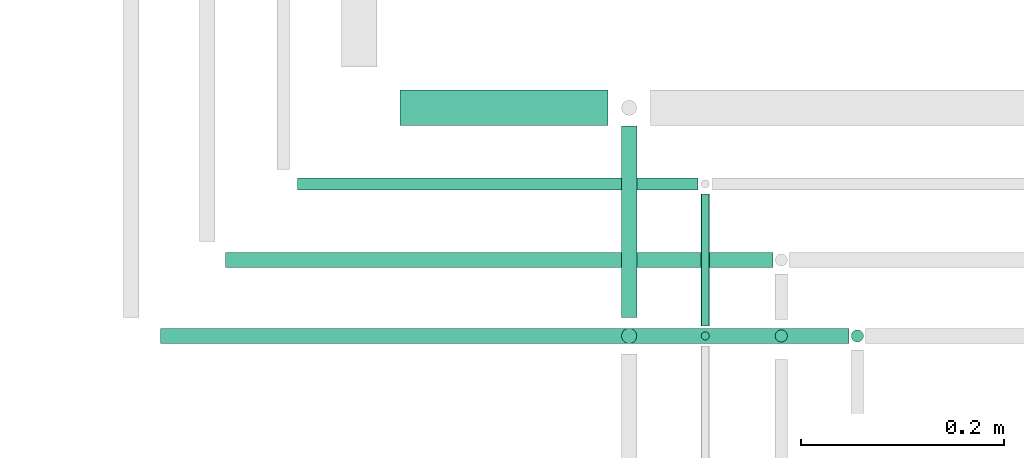
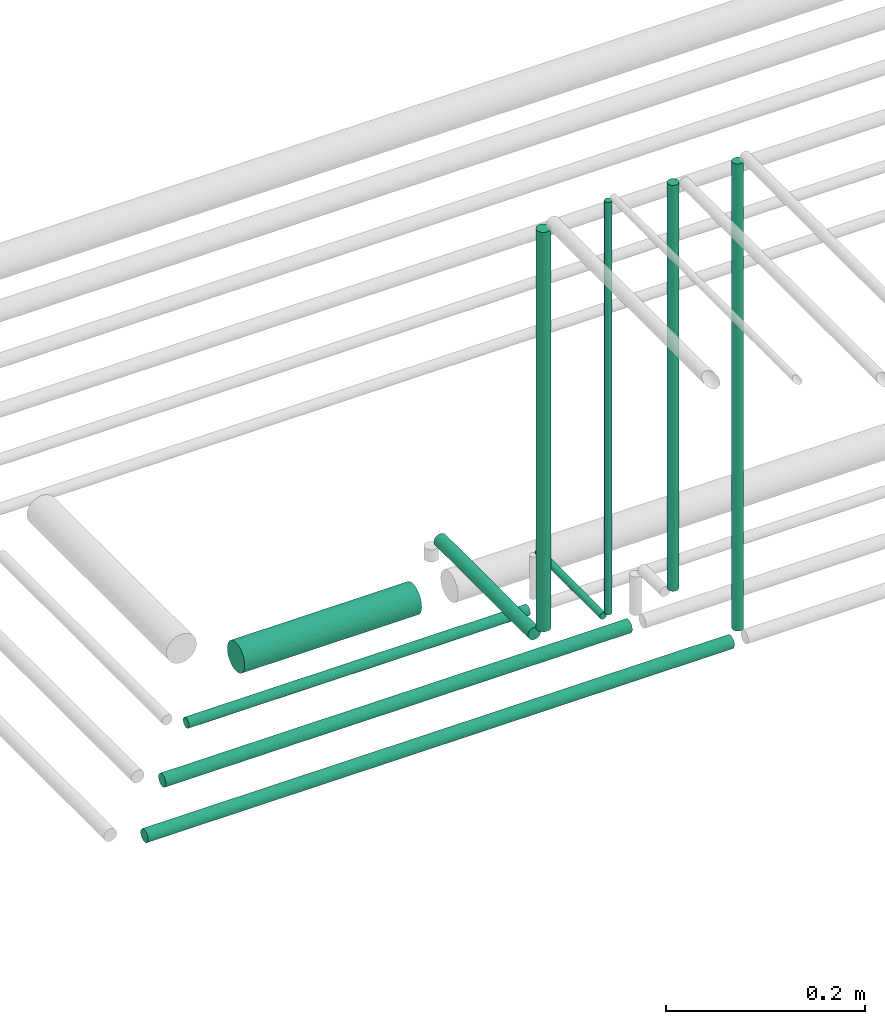
# One storey, part 41 of 65: 10 flow segments.
"""IFC2X3 building model written with IfcOpenShell, lengths in millimetres."""

from ifc_helpers import new_model, entity, si_unit, converted_unit, derived_unit, direction, frame, frame_2d, origin, origin_2d_with_axis, place, context, subcontext, project, spatial, circle, extrude, type_object, element, save


model = new_model("IFC2X3")

# Units and contexts
model_context = context("Model", 3, precision=0.01, world=origin(), true_north=direction((6.12303176911189e-17, 1.0)))
body_context = subcontext(model_context, "Body", "Model", "MODEL_VIEW")
ifc_project = project(units=[si_unit("LENGTHUNIT", "METRE", prefix="MILLI"), si_unit("AREAUNIT", "SQUARE_METRE"), si_unit("VOLUMEUNIT", "CUBIC_METRE"), converted_unit("PLANEANGLEUNIT", "DEGREE", entity("IfcRatioMeasure", 0.0174532925199433), si_unit("PLANEANGLEUNIT", "RADIAN"), dimensions=[0, 0, 0, 0, 0, 0, 0]), si_unit("MASSUNIT", "GRAM", prefix="KILO"), derived_unit("MASSDENSITYUNIT", [(si_unit("MASSUNIT", "GRAM", prefix="KILO"), 1), (si_unit("LENGTHUNIT", "METRE"), -3)]), derived_unit("MOMENTOFINERTIAUNIT", [(si_unit("LENGTHUNIT", "METRE"), 4)]), si_unit("TIMEUNIT", "SECOND"), si_unit("FREQUENCYUNIT", "HERTZ"), si_unit("THERMODYNAMICTEMPERATUREUNIT", "DEGREE_CELSIUS"), derived_unit("THERMALTRANSMITTANCEUNIT", [(si_unit("MASSUNIT", "GRAM", prefix="KILO"), 1), (si_unit("THERMODYNAMICTEMPERATUREUNIT", "KELVIN"), -1), (si_unit("TIMEUNIT", "SECOND"), -3)]), derived_unit("VOLUMETRICFLOWRATEUNIT", [(si_unit("LENGTHUNIT", "METRE"), 3), (si_unit("TIMEUNIT", "SECOND"), -1)]), derived_unit("MASSFLOWRATEUNIT", [(si_unit("MASSUNIT", "GRAM", prefix="KILO"), 1), (si_unit("TIMEUNIT", "SECOND"), -1)]), derived_unit("ROTATIONALFREQUENCYUNIT", [(si_unit("TIMEUNIT", "SECOND"), -1)]), si_unit("ELECTRICCURRENTUNIT", "AMPERE"), si_unit("ELECTRICVOLTAGEUNIT", "VOLT"), si_unit("POWERUNIT", "WATT"), si_unit("FORCEUNIT", "NEWTON", prefix="KILO"), si_unit("ILLUMINANCEUNIT", "LUX"), si_unit("LUMINOUSFLUXUNIT", "LUMEN"), si_unit("LUMINOUSINTENSITYUNIT", "CANDELA"), derived_unit("USERDEFINED", [(si_unit("MASSUNIT", "GRAM", prefix="KILO"), -1), (si_unit("LENGTHUNIT", "METRE"), -2), (si_unit("TIMEUNIT", "SECOND"), 3), (si_unit("LUMINOUSFLUXUNIT", "LUMEN"), 1)]), derived_unit("LINEARVELOCITYUNIT", [(si_unit("LENGTHUNIT", "METRE"), 1), (si_unit("TIMEUNIT", "SECOND"), -1)]), si_unit("PRESSUREUNIT", "PASCAL"), derived_unit("USERDEFINED", [(si_unit("LENGTHUNIT", "METRE"), -2), (si_unit("MASSUNIT", "GRAM", prefix="KILO"), 1), (si_unit("TIMEUNIT", "SECOND"), -2)]), derived_unit("LINEARFORCEUNIT", [(si_unit("MASSUNIT", "GRAM", prefix="KILO"), 1), (si_unit("LENGTHUNIT", "METRE"), 1), (si_unit("TIMEUNIT", "SECOND"), -2), (si_unit("LENGTHUNIT", "METRE"), -1)]), derived_unit("PLANARFORCEUNIT", [(si_unit("MASSUNIT", "GRAM", prefix="KILO"), 1), (si_unit("LENGTHUNIT", "METRE"), 1), (si_unit("TIMEUNIT", "SECOND"), -2), (si_unit("LENGTHUNIT", "METRE"), -2)])], contexts=[model_context])

# Site, building, storey
site_placement = place(None, frame((0.0, -0.00077364408347762, 0.0)))
site = spatial("IfcSite", under=ifc_project, at=site_placement, CompositionType="ELEMENT")
building_placement = place(site_placement, origin())
building = spatial("IfcBuilding", under=site, at=building_placement, CompositionType="ELEMENT")
storey_placement = place(building_placement, frame((0.0, 0.0, 19800.0)))
storey = spatial("IfcBuildingStorey", under=building, at=storey_placement, CompositionType="ELEMENT", Elevation=19800.0)

# Flow segments
pipe_segment_type = type_object("IfcPipeSegmentType", PredefinedType="NOTDEFINED")
flow_segment_1_placement = place(storey_placement, frame((56088.0006591797, 7730.90472776407, 2540.90472776409)))
element("IfcFlowSegment", 1, at=flow_segment_1_placement, inside=storey, type_object=pipe_segment_type, context=body_context, shape_type="SweptSolid", body=[
    extrude(circle(Radius=7.5, at=frame_2d((-5.41433564649196e-12, 0.0), x_axis=(1.0, 0.0))), frame((0.0, 9.09527223592177, 9.09527223591419), z_axis=(1.0, 0.0, 0.0), x_axis=(0.0, 1.0, 0.0)), (0.0, 0.0, 1.0), 540.107875743126),
])
flow_segment_2_placement = place(storey_placement, frame((56159.0006591797, 7807.40472776405, 2542.40472776409)))
element("IfcFlowSegment", 2, at=flow_segment_2_placement, inside=storey, type_object=pipe_segment_type, context=body_context, shape_type="SweptSolid", body=[
    extrude(circle(Radius=6.0, at=frame_2d((-1.84087411980727e-11, 0.0), x_axis=(1.0, 0.0))), frame((0.0, 7.59527223593403, 7.59527223591454), z_axis=(1.0, 0.0, 0.0), x_axis=(0.0, 1.0, 0.0)), (0.0, 0.0, 1.0), 395.107875743133),
])
flow_segment_3_placement = place(storey_placement, frame((56024.0006591797, 7655.90472776407, 2540.90472776409)))
element("IfcFlowSegment", 3, at=flow_segment_3_placement, inside=storey, type_object=pipe_segment_type, context=body_context, shape_type="SweptSolid", body=[
    extrude(circle(Radius=7.5, at=frame_2d((-6.49720277579036e-12, 0.0), x_axis=(1.0, 0.0))), frame((0.0, 9.09527223592286, 9.09527223591419), z_axis=(1.0, 0.0, 0.0), x_axis=(0.0, 1.0, 0.0)), (0.0, 0.0, 1.0), 679.107875743112),
])
flow_segment_4_placement = place(storey_placement, frame((56260.0006591797, 7870.90472776409, 2530.9047277641)))
element("IfcFlowSegment", 4, at=flow_segment_4_placement, inside=storey, type_object=pipe_segment_type, context=body_context, shape_type="SweptSolid", body=[
    extrude(circle(Radius=17.5, at=frame_2d((-2.16573425859679e-12, 0.0), x_axis=(1.0, 0.0))), frame((0.0, 19.0952722359184, 19.0952722359163), z_axis=(1.0, 0.0, 0.0), x_axis=(0.0, 1.0, 0.0)), (0.0, 0.0, 1.0), 205.107875743124),
])
flow_segment_5_placement = place(storey_placement, frame((56477.0132626869, 7683.0, 2615.9047277641)))
element("IfcFlowSegment", 5, at=flow_segment_5_placement, inside=storey, type_object=pipe_segment_type, context=body_context, shape_type="SweptSolid", body=[
    extrude(circle(Radius=7.5, at=frame_2d((8.66293703438714e-12, 0.0), x_axis=(1.0, 0.0))), frame((9.09527223592286, 0.0, 9.09527223591419), z_axis=(0.0, 1.0, 0.0), x_axis=(-1.0, 0.0, 0.0)), (0.0, 0.0, 1.0), 189.000000000023),
])
flow_segment_6_placement = place(storey_placement, frame((56477.0132626869, 7655.90472776408, 2643.0)))
element("IfcFlowSegment", 6, at=flow_segment_6_placement, inside=storey, type_object=pipe_segment_type, context=body_context, shape_type="SweptSolid", body=[
    extrude(circle(Radius=7.5, at=origin_2d_with_axis()), frame((9.09527223591419, 9.09527223591636, 0.0), z_axis=(0.0, 0.0, 1.0), x_axis=(-1.0, 0.0, 0.0)), (0.0, 0.0, 1.0), 489.000000000036),
])
flow_segment_7_placement = place(storey_placement, frame((56555.5132626869, 7659.40472776405, 2635.0)))
element("IfcFlowSegment", 7, at=flow_segment_7_placement, inside=storey, type_object=pipe_segment_type, context=body_context, shape_type="SweptSolid", body=[
    extrude(circle(Radius=4.0, at=frame_2d((0.0, 1.08286712929839e-12), x_axis=(1.0, 0.0))), frame((5.59527223591499, 5.59527223591716, 0.0), z_axis=(0.0, 0.0, 1.0), x_axis=(-1.0, 0.0, 0.0)), (0.0, 0.0, 1.0), 505.000000000145),
])
flow_segment_8_placement = place(storey_placement, frame((56555.5132626869, 7675.0, 2619.40472776393)))
element("IfcFlowSegment", 8, at=flow_segment_8_placement, inside=storey, type_object=pipe_segment_type, context=body_context, shape_type="SweptSolid", body=[
    extrude(circle(Radius=4.0, at=origin_2d_with_axis()), frame((5.59527223591499, 0.0, 5.59527223591499), z_axis=(0.0, 1.0, 0.0), x_axis=(1.0, 0.0, 0.0)), (0.0, 0.0, 1.0), 130.000000000026),
])
flow_segment_9_placement = place(storey_placement, frame((56628.5132626869, 7657.40472776405, 2639.0)))
element("IfcFlowSegment", 9, at=flow_segment_9_placement, inside=storey, type_object=pipe_segment_type, context=body_context, shape_type="SweptSolid", body=[
    extrude(circle(Radius=6.0, at=frame_2d((0.0, 1.08286712929839e-12), x_axis=(1.0, 0.0))), frame((7.59527223591454, 7.5952722359167, 0.0), z_axis=(0.0, 0.0, 1.0), x_axis=(-1.0, 0.0, 0.0)), (0.0, 0.0, 1.0), 497.000000000143),
])
flow_segment_10_placement = place(storey_placement, frame((56703.5132626869, 7657.40472776407, 2564.0)))
element("IfcFlowSegment", 10, at=flow_segment_10_placement, inside=storey, type_object=pipe_segment_type, context=body_context, shape_type="SweptSolid", body=[
    extrude(circle(Radius=6.0, at=origin_2d_with_axis()), frame((7.59527223591454, 7.59527223591562, 0.0), z_axis=(0.0, 0.0, 1.0), x_axis=(-1.0, 0.0, 0.0)), (0.0, 0.0, 1.0), 572.000000000009),
])

save(model, "model.ifc")
